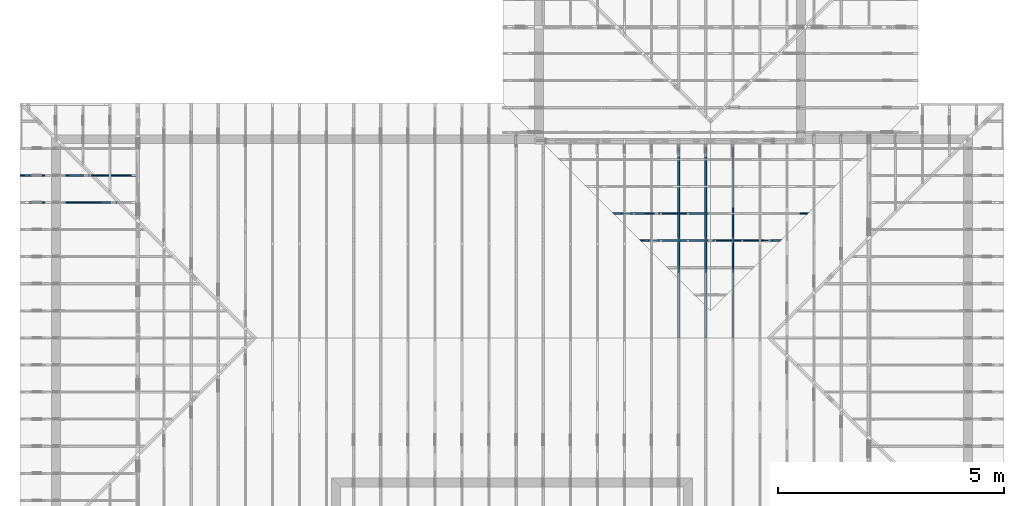
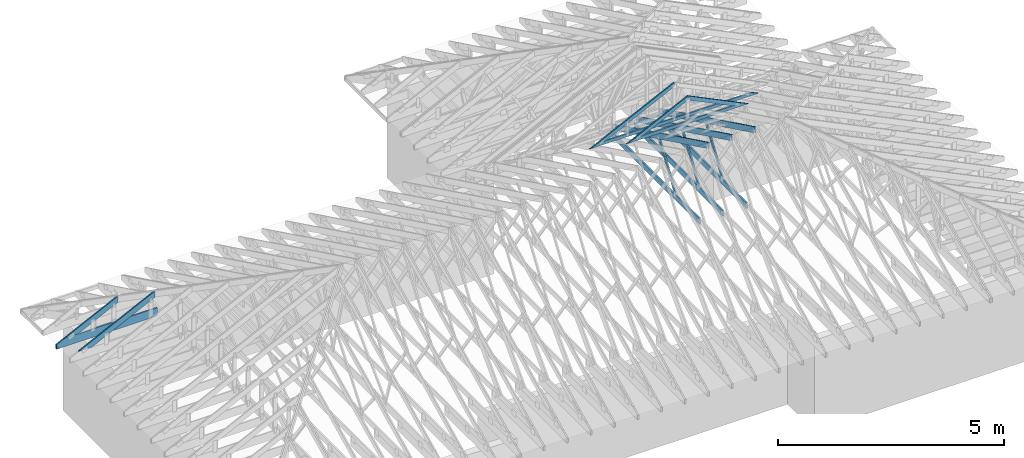
# One storey, part 19 of 159: 17 members, 7 elements without a shape of their own.
"""IFC2X3 building model written with IfcOpenShell, lengths in millimetres."""

from ifc_helpers import new_model, si_unit, frame, origin, origin_with_axes, origin_2d, place, context, project, spatial, faceted_brep, element, aggregate, save


model = new_model("IFC2X3")

# Units and contexts
model_context = context("Model", 3, precision=1e-05, world=origin())
plan_context = context("Plan", 2, precision=1e-05, world=origin_2d())
ifc_project = project(units=[si_unit("LENGTHUNIT", "METRE", prefix="MILLI"), si_unit("AREAUNIT", "SQUARE_METRE"), si_unit("VOLUMEUNIT", "CUBIC_METRE"), si_unit("SOLIDANGLEUNIT", "STERADIAN"), si_unit("PLANEANGLEUNIT", "RADIAN"), si_unit("MASSUNIT", "GRAM"), si_unit("TIMEUNIT", "SECOND"), si_unit("THERMODYNAMICTEMPERATUREUNIT", "DEGREE_CELSIUS"), si_unit("LUMINOUSINTENSITYUNIT", "LUMEN")], contexts=[model_context, plan_context])

# Site, building, storey
site_placement = place(None, origin_with_axes())
site = spatial("IfcSite", under=ifc_project, at=site_placement, CompositionType="ELEMENT")
building_placement = place(site_placement, origin_with_axes())
building = spatial("IfcBuilding", under=site, at=building_placement, Name="Plan 1", CompositionType="ELEMENT")
storey_placement = place(building_placement, origin_with_axes())
storey = spatial("IfcBuildingStorey", under=building, at=storey_placement, Name="Etasje 1", CompositionType="ELEMENT", Elevation=0.0)

# Assembly, members
assembly_1_placement = place(storey_placement, frame((15075.02226140475, -699.9989301294845, 1.1021457184401395e-15), z_axis=(-1.0, 1.836909530733566e-16, 6.123031769111886e-17), x_axis=(-1.836909530733566e-16, -1.0, 0.0)))
assembly_1 = element("IfcElementAssembly", 1, at=assembly_1_placement, inside=storey, Name="T7 (103)", AssemblyPlace="FACTORY", PredefinedType="TRUSS")
member_1_placement = place(assembly_1_placement, frame((-9411.999005287185, 437.2146234308699, -36.00000000000001), z_axis=(0.0, 0.0, 1.0), x_axis=(0.8987940462991673, 0.43837114678907735, 0.0)))
member_1 = element("IfcMember", 2, at=member_1_placement, Name="T7-O11", context=model_context, shape_type="Brep", body=[
    faceted_brep([(4758.463277584195, 148.00009154954296, 36.0), (72.18442876594781, 148.00009154954296, 36.0), (0.0, 4.140399232710479e-05, 36.0), (4686.278875574299, 4.140399232710479e-05, 36.0), (72.18442876594781, 148.00009154954296, 8.839751011381847e-15), (4758.463277584195, 148.00009154954296, 5.82724436416006e-13), (4686.278875574299, 4.140399232710479e-05, 5.738846886811872e-13), (0.0, 4.140399232710479e-05, 0.0), (8.360351420234293e-05, 5.140324472498181e-15, 7.179836740020234e-31), (8.360351420432413e-05, 4.174029286270475e-15, 36.0), (72.18450667705471, 147.99999999603824, 36.0), (72.18450667705471, 147.99999999603824, 1.530729119798975e-30), (4686.27888374885, 4.514103814251943e-05, -1.8242490005659002e-29), (4686.27888374885, 4.514103814472372e-05, 36.0), (8.360351421288216e-05, 2.204296752011599e-15, 36.0), (8.360351421288216e-05, 5.315131319929112e-21, -3.254471682622608e-37), (4758.463306857064, 148.00004514198963, 1.58299098763632e-28), (4758.463306857064, 148.00004514198963, 36.0), (4686.2788837488515, 4.5141036935092416e-05, 36.0), (4686.2788837488515, 4.5141036935092416e-05, 1.0730458735393999e-28), (72.18450667705474, 147.99999999603824, 0.0), (72.18450667705474, 147.99999999603824, 36.0), (4758.463306857063, 148.00004514199048, 36.0), (4758.463306857063, 148.00004514199048, -2.8398992587956425e-29)], [[[0, 1, 2, 3]], [[4, 5, 6, 7]], [[8, 9, 10, 11]], [[12, 13, 14, 15]], [[16, 17, 18, 19]], [[20, 21, 22, 23]]]),
])
member_2_placement = place(assembly_1_placement, frame((-5591.18115234375, 371.0, -36.0), z_axis=(0.0, 0.0, 1.0), x_axis=(-1.0, 1.2246063538223773e-16, 0.0)))
member_2 = element("IfcMember", 3, at=member_2_placement, Name="T7-U39", context=model_context, shape_type="Brep", body=[
    faceted_brep([(3910.81787109375, 148.00000000000048, 36.0), (0.0, 148.00000000000048, 36.0), (0.0, 0.0, 36.0), (3910.81787109375, 0.0, 36.0), (0.0, 148.00000000000048, 0.0), (3910.81787109375, 148.00000000000048, 4.789212413583509e-13), (3910.81787109375, 0.0, 4.789212413583509e-13), (0.0, 0.0, 0.0), (0.0001433398574590683, 3.979039320256561e-13, 0.0), (0.0001433398574612726, 3.979039320256561e-13, 36.0), (0.00014333985747939676, 148.00000000000037, 36.0), (0.00014333985747719247, 148.00000000000037, -1.1097494219785373e-30), (3910.817777776101, -3.204779149536956e-13, 4.746728930957506e-29), (3910.817777776101, -3.182736235168153e-13, 36.0), (0.0001433398574590683, 4.001081950488681e-13, 36.0), (0.0001433398574590683, 3.9790390361198783e-13, 1.73977793531565e-36), (3910.817777776101, 148.00000000000048, 0.0), (3910.817777776101, 148.00000000000048, 36.0), (3910.817777776101, 4.547473508864641e-13, 36.0), (3910.817777776101, 4.547473508864641e-13, 0.0), (0.0001433398574590683, 148.00000000000037, 0.0), (0.0001433398574590683, 148.00000000000037, 36.0), (3910.817777776101, 148.0000000000001, 36.0), (3910.817777776101, 148.00000000000014, -2.208810534618833e-29)], [[[0, 1, 2, 3]], [[4, 5, 6, 7]], [[8, 9, 10, 11]], [[12, 13, 14, 15]], [[16, 17, 18, 19]], [[20, 21, 22, 23]]]),
])
member_3_placement = place(assembly_1_placement, frame((-7407.03695472166, 1415.0999762480442, -36.0), z_axis=(0.0, 0.0, 1.0), x_axis=(0.5642475050064201, -0.8256056886274645, 0.0)))
member_3 = element("IfcMember", 4, at=member_3_placement, Name="T7-D42", context=model_context, shape_type="Brep", body=[
    faceted_brep([(1236.1859046255386, 72.99999679664234, 36.0), (10.714742691100582, 72.99999679664234, 36.0), (8.80134111866937e-05, 0.0003439493775658775, 36.0), (1264.647265190018, 0.0003439493775658775, 36.0), (10.714742691100582, 72.99999679664234, 1.312134197909365e-15), (1236.1859046255386, 72.99999679664234, 1.5138411133100978e-13), (1264.647265190018, 0.0003439493775658775, 1.548695076295789e-13), (8.80134111866937e-05, 0.0003439493775658775, 1.077817825608066e-20), (1.2441219929271163e-16, 0.00017519218454252033, -7.699393958337917e-33), (2.305335691224139e-15, 0.00017519218454220022, 36.0), (10.714685884795475, 73.00017519218454, 36.0), (10.714685884795474, 73.00017519218454, -2.956283656724794e-32), (1264.6473849224226, 0.00017519218655669935, 4.373824669985916e-29), (1264.6473849224226, 0.00017519218655890365, 36.0), (-3.510681399126273e-30, 0.0001751921845447429, 36.0), (0.0, 0.0001751921845425386, 0.0), (1236.1860298802894, 73.00017519218727, -1.3795914725131465e-29), (1236.1860298802894, 73.00017519218727, 36.0), (1264.6473849224226, 0.0001751921872710227, 36.0), (1264.6473849224226, 0.0001751921872710227, -1.4037355718167356e-29), (10.714685884795474, 73.00017519218454, 0.0), (10.714685884795474, 73.00017519218453, 36.0), (1236.1860298802894, 73.00017519218719, 36.0), (1236.1860298802894, 73.00017519218719, -5.5220263365470826e-30)], [[[0, 1, 2, 3]], [[4, 5, 6, 7]], [[8, 9, 10, 11]], [[12, 13, 14, 15]], [[16, 17, 18, 19]], [[20, 21, 22, 23]]]),
])
aggregate(assembly_1, [member_1, member_2, member_3])

assembly_2_placement = place(storey_placement, frame((14475.022261404752, -699.9989301294836, 1.1021457184401395e-15), z_axis=(-1.0, 1.836909530733566e-16, 6.123031769111886e-17), x_axis=(-1.836909530733566e-16, -1.0, 0.0)))
assembly_2 = element("IfcElementAssembly", 5, at=assembly_2_placement, inside=storey, Name="T10 (102)", AssemblyPlace="FACTORY", PredefinedType="TRUSS")
member_4_placement = place(assembly_2_placement, frame((-9411.999005287185, 437.2146234308699, -36.00000000000001), z_axis=(0.0, 0.0, 1.0), x_axis=(0.8987940462991673, 0.43837114678907735, 0.0)))
member_4 = element("IfcMember", 6, at=member_4_placement, Name="T10-O11", context=model_context, shape_type="Brep", body=[
    faceted_brep([(4758.463277584195, 148.00009154954296, 36.0), (72.18442876594781, 148.00009154954296, 36.0), (0.0, 4.140399232710479e-05, 36.0), (4686.278875574299, 4.140399232710479e-05, 36.0), (72.18442876594781, 148.00009154954296, 8.839751011381847e-15), (4758.463277584195, 148.00009154954296, 5.82724436416006e-13), (4686.278875574299, 4.140399232710479e-05, 5.738846886811872e-13), (0.0, 4.140399232710479e-05, 0.0), (8.360351420234293e-05, 5.140324472498181e-15, 7.179836740020234e-31), (8.360351420432413e-05, 4.174029286270475e-15, 36.0), (72.18450667705471, 147.99999999603824, 36.0), (72.18450667705471, 147.99999999603824, 1.530729119798975e-30), (4686.27888374885, 4.514103814251943e-05, -1.8242490005659002e-29), (4686.27888374885, 4.514103814472372e-05, 36.0), (8.360351421288216e-05, 2.204296752011599e-15, 36.0), (8.360351421288216e-05, 5.315131319929112e-21, -3.254471682622608e-37), (4758.463306857064, 148.00004514198963, 1.58299098763632e-28), (4758.463306857064, 148.00004514198963, 36.0), (4686.2788837488515, 4.5141036935092416e-05, 36.0), (4686.2788837488515, 4.5141036935092416e-05, 1.0730458735393999e-28), (72.18450667705474, 147.99999999603824, 0.0), (72.18450667705474, 147.99999999603824, 36.0), (4758.463306857063, 148.00004514199048, 36.0), (4758.463306857063, 148.00004514199048, -2.8398992587956425e-29)], [[[0, 1, 2, 3]], [[4, 5, 6, 7]], [[8, 9, 10, 11]], [[12, 13, 14, 15]], [[16, 17, 18, 19]], [[20, 21, 22, 23]]]),
])
member_5_placement = place(assembly_2_placement, frame((-5591.18115234375, 371.0, -36.0), z_axis=(0.0, 0.0, 1.0), x_axis=(-1.0, 1.2246063538223773e-16, 0.0)))
member_5 = element("IfcMember", 7, at=member_5_placement, Name="T10-U39", context=model_context, shape_type="Brep", body=[
    faceted_brep([(3910.81787109375, 148.00000000000048, 36.0), (0.0, 148.00000000000048, 36.0), (0.0, 0.0, 36.0), (3910.81787109375, 0.0, 36.0), (0.0, 148.00000000000048, 0.0), (3910.81787109375, 148.00000000000048, 4.789212413583509e-13), (3910.81787109375, 0.0, 4.789212413583509e-13), (0.0, 0.0, 0.0), (0.0001433398574590683, 3.979039320256561e-13, 0.0), (0.0001433398574612726, 3.979039320256561e-13, 36.0), (0.00014333985747939676, 148.00000000000037, 36.0), (0.00014333985747719247, 148.00000000000037, -1.1097494219785373e-30), (3910.817777776101, -3.204779149536956e-13, 4.746728930957506e-29), (3910.817777776101, -3.182736235168153e-13, 36.0), (0.0001433398574590683, 4.001081950488681e-13, 36.0), (0.0001433398574590683, 3.9790390361198783e-13, 1.73977793531565e-36), (3910.817777776101, 148.00000000000048, 0.0), (3910.817777776101, 148.00000000000048, 36.0), (3910.817777776101, 4.547473508864641e-13, 36.0), (3910.817777776101, 4.547473508864641e-13, 0.0), (0.0001433398574590683, 148.00000000000037, 0.0), (0.0001433398574590683, 148.00000000000037, 36.0), (3910.817777776101, 148.0000000000001, 36.0), (3910.817777776101, 148.00000000000014, -2.208810534618833e-29)], [[[0, 1, 2, 3]], [[4, 5, 6, 7]], [[8, 9, 10, 11]], [[12, 13, 14, 15]], [[16, 17, 18, 19]], [[20, 21, 22, 23]]]),
])
member_6_placement = place(assembly_2_placement, frame((-7407.03695472166, 1415.0999762480442, -36.0), z_axis=(0.0, 0.0, 1.0), x_axis=(0.5642475050064201, -0.8256056886274645, 0.0)))
member_6 = element("IfcMember", 8, at=member_6_placement, Name="T10-D42", context=model_context, shape_type="Brep", body=[
    faceted_brep([(1236.1859046255386, 72.99999679664234, 36.0), (10.714742691100582, 72.99999679664234, 36.0), (8.80134111866937e-05, 0.0003439493775658775, 36.0), (1264.647265190018, 0.0003439493775658775, 36.0), (10.714742691100582, 72.99999679664234, 1.312134197909365e-15), (1236.1859046255386, 72.99999679664234, 1.5138411133100978e-13), (1264.647265190018, 0.0003439493775658775, 1.548695076295789e-13), (8.80134111866937e-05, 0.0003439493775658775, 1.077817825608066e-20), (1.2441219929271163e-16, 0.00017519218454252033, -7.699393958337917e-33), (2.305335691224139e-15, 0.00017519218454220022, 36.0), (10.714685884795475, 73.00017519218454, 36.0), (10.714685884795474, 73.00017519218454, -2.956283656724794e-32), (1264.6473849224226, 0.00017519218655669935, 4.373824669985916e-29), (1264.6473849224226, 0.00017519218655890365, 36.0), (-3.510681399126273e-30, 0.0001751921845447429, 36.0), (0.0, 0.0001751921845425386, 0.0), (1236.1860298802894, 73.00017519218727, -1.3795914725131465e-29), (1236.1860298802894, 73.00017519218727, 36.0), (1264.6473849224226, 0.0001751921872710227, 36.0), (1264.6473849224226, 0.0001751921872710227, -1.4037355718167356e-29), (10.714685884795474, 73.00017519218454, 0.0), (10.714685884795474, 73.00017519218453, 36.0), (1236.1860298802894, 73.00017519218719, 36.0), (1236.1860298802894, 73.00017519218719, -5.5220263365470826e-30)], [[[0, 1, 2, 3]], [[4, 5, 6, 7]], [[8, 9, 10, 11]], [[12, 13, 14, 15]], [[16, 17, 18, 19]], [[20, 21, 22, 23]]]),
])
aggregate(assembly_2, [member_4, member_5, member_6])

assembly_3_placement = place(storey_placement, frame((13875.022261404752, -699.9989301294836, 1.1021457184401395e-15), z_axis=(-1.0, 1.836909530733566e-16, 6.123031769111886e-17), x_axis=(-1.836909530733566e-16, -1.0, 0.0)))
assembly_3 = element("IfcElementAssembly", 9, at=assembly_3_placement, inside=storey, Name="T6 (101)", AssemblyPlace="FACTORY", PredefinedType="TRUSS")
member_7_placement = place(assembly_3_placement, frame((-9411.999005287185, 437.2146234308699, -36.00000000000001), z_axis=(0.0, 0.0, 1.0), x_axis=(0.8987940462991673, 0.43837114678907735, 0.0)))
member_7 = element("IfcMember", 10, at=member_7_placement, Name="T6-O11", context=model_context, shape_type="Brep", body=[
    faceted_brep([(4758.463277584195, 148.00009154954296, 36.0), (72.18442876594781, 148.00009154954296, 36.0), (0.0, 4.140399232710479e-05, 36.0), (4686.278875574299, 4.140399232710479e-05, 36.0), (72.18442876594781, 148.00009154954296, 8.839751011381847e-15), (4758.463277584195, 148.00009154954296, 5.82724436416006e-13), (4686.278875574299, 4.140399232710479e-05, 5.738846886811872e-13), (0.0, 4.140399232710479e-05, 0.0), (8.360351420234293e-05, 5.140324472498181e-15, 7.179836740020234e-31), (8.360351420432413e-05, 4.174029286270475e-15, 36.0), (72.18450667705471, 147.99999999603824, 36.0), (72.18450667705471, 147.99999999603824, 1.530729119798975e-30), (4686.27888374885, 4.514103814251943e-05, -1.8242490005659002e-29), (4686.27888374885, 4.514103814472372e-05, 36.0), (8.360351421288216e-05, 2.204296752011599e-15, 36.0), (8.360351421288216e-05, 5.315131319929112e-21, -3.254471682622608e-37), (4758.463306857064, 148.00004514198963, 1.58299098763632e-28), (4758.463306857064, 148.00004514198963, 36.0), (4686.2788837488515, 4.5141036935092416e-05, 36.0), (4686.2788837488515, 4.5141036935092416e-05, 1.0730458735393999e-28), (72.18450667705474, 147.99999999603824, 0.0), (72.18450667705474, 147.99999999603824, 36.0), (4758.463306857063, 148.00004514199048, 36.0), (4758.463306857063, 148.00004514199048, -2.8398992587956425e-29)], [[[0, 1, 2, 3]], [[4, 5, 6, 7]], [[8, 9, 10, 11]], [[12, 13, 14, 15]], [[16, 17, 18, 19]], [[20, 21, 22, 23]]]),
])
member_8_placement = place(assembly_3_placement, frame((-5591.18115234375, 371.0, -36.0), z_axis=(0.0, 0.0, 1.0), x_axis=(-1.0, 1.2246063538223773e-16, 0.0)))
member_8 = element("IfcMember", 11, at=member_8_placement, Name="T6-U39", context=model_context, shape_type="Brep", body=[
    faceted_brep([(3910.81787109375, 148.00000000000048, 36.0), (0.0, 148.00000000000048, 36.0), (0.0, 0.0, 36.0), (3910.81787109375, 0.0, 36.0), (0.0, 148.00000000000048, 0.0), (3910.81787109375, 148.00000000000048, 4.789212413583509e-13), (3910.81787109375, 0.0, 4.789212413583509e-13), (0.0, 0.0, 0.0), (0.0001433398574590683, 3.979039320256561e-13, 0.0), (0.0001433398574612726, 3.979039320256561e-13, 36.0), (0.00014333985747939676, 148.00000000000037, 36.0), (0.00014333985747719247, 148.00000000000037, -1.1097494219785373e-30), (3910.817777776101, -3.204779149536956e-13, 4.746728930957506e-29), (3910.817777776101, -3.182736235168153e-13, 36.0), (0.0001433398574590683, 4.001081950488681e-13, 36.0), (0.0001433398574590683, 3.9790390361198783e-13, 1.73977793531565e-36), (3910.817777776101, 148.00000000000048, 0.0), (3910.817777776101, 148.00000000000048, 36.0), (3910.817777776101, 4.547473508864641e-13, 36.0), (3910.817777776101, 4.547473508864641e-13, 0.0), (0.0001433398574590683, 148.00000000000037, 0.0), (0.0001433398574590683, 148.00000000000037, 36.0), (3910.817777776101, 148.0000000000001, 36.0), (3910.817777776101, 148.00000000000014, -2.208810534618833e-29)], [[[0, 1, 2, 3]], [[4, 5, 6, 7]], [[8, 9, 10, 11]], [[12, 13, 14, 15]], [[16, 17, 18, 19]], [[20, 21, 22, 23]]]),
])
member_9_placement = place(assembly_3_placement, frame((-7407.03695472166, 1415.0999762480442, -36.0), z_axis=(0.0, 0.0, 1.0), x_axis=(0.5642475050064201, -0.8256056886274645, 0.0)))
member_9 = element("IfcMember", 12, at=member_9_placement, Name="T6-D42", context=model_context, shape_type="Brep", body=[
    faceted_brep([(1236.1859046255386, 72.99999679664234, 36.0), (10.714742691100582, 72.99999679664234, 36.0), (8.80134111866937e-05, 0.0003439493775658775, 36.0), (1264.647265190018, 0.0003439493775658775, 36.0), (10.714742691100582, 72.99999679664234, 1.312134197909365e-15), (1236.1859046255386, 72.99999679664234, 1.5138411133100978e-13), (1264.647265190018, 0.0003439493775658775, 1.548695076295789e-13), (8.80134111866937e-05, 0.0003439493775658775, 1.077817825608066e-20), (1.2441219929271163e-16, 0.00017519218454252033, -7.699393958337917e-33), (2.305335691224139e-15, 0.00017519218454220022, 36.0), (10.714685884795475, 73.00017519218454, 36.0), (10.714685884795474, 73.00017519218454, -2.956283656724794e-32), (1264.6473849224226, 0.00017519218655669935, 4.373824669985916e-29), (1264.6473849224226, 0.00017519218655890365, 36.0), (-3.510681399126273e-30, 0.0001751921845447429, 36.0), (0.0, 0.0001751921845425386, 0.0), (1236.1860298802894, 73.00017519218727, -1.3795914725131465e-29), (1236.1860298802894, 73.00017519218727, 36.0), (1264.6473849224226, 0.0001751921872710227, 36.0), (1264.6473849224226, 0.0001751921872710227, -1.4037355718167356e-29), (10.714685884795474, 73.00017519218454, 0.0), (10.714685884795474, 73.00017519218453, 36.0), (1236.1860298802894, 73.00017519218719, 36.0), (1236.1860298802894, 73.00017519218719, -5.5220263365470826e-30)], [[[0, 1, 2, 3]], [[4, 5, 6, 7]], [[8, 9, 10, 11]], [[12, 13, 14, 15]], [[16, 17, 18, 19]], [[20, 21, 22, 23]]]),
])
aggregate(assembly_3, [member_7, member_8, member_9])

assembly_4_placement = place(storey_placement, frame((-700.000000000007, 8081.993668449246, 1.1021457184401395e-15), z_axis=(0.0, -1.0, 6.123031769111886e-17), x_axis=(1.0, 0.0, 0.0)))
assembly_4 = element("IfcElementAssembly", 13, at=assembly_4_placement, inside=storey, Name="S7 (14)", AssemblyPlace="FACTORY", PredefinedType="TRUSS")
member_10_placement = place(assembly_4_placement, frame((276.06017491049846, 89.97845651718738, -36.000000217690726), z_axis=(0.0, 0.0, 1.0), x_axis=(0.898794046299167, 0.4383711467890774, 0.0)))
member_10 = element("IfcMember", 14, at=member_10_placement, Name="S7-O62", context=model_context, shape_type="Brep", body=[
    faceted_brep([(1508.5918787073251, 147.99999481679464, 36.00000324769576), (1436.4074547564246, 2.2737367544323206e-13, 36.000000217691195), (1396.3537848139886, 3.2104094316309784e-07, 4.547473508864641e-13), (1468.5382087648895, 147.99999513783558, 3.030005132131919e-06), (8.09896368423324e-05, 148.0000000009527, 2.1769072588995184e-07), (8.09896368423324e-05, 148.0000000009528, 36.00000021769072), (1508.5918778646371, 148.00000000095272, 36.00000021769072), (1468.5382088888068, 148.0000000009526, 2.1769072588995184e-07), (0.0, 148.00000000096017, 2.1769072588995186e-07), (1468.5382080078125, 148.00000000096017, 2.176909057280739e-07), (1396.3537826538088, 9.52809386944864e-10, 2.176908968883233e-07), (303.44506835937506, 9.52809386944864e-10, 2.1769076305002775e-07), (303.4450247385612, 8.118661298794905e-10, 2.1769072588995186e-07), (303.4450247385612, 8.118661298794905e-10, 36.000000217690726), (5.302542993490533e-05, 148.0000015417521, 36.000000217690726), (5.302542993490533e-05, 148.0000015417521, 2.1769072588995186e-07), (1436.4074538754444, 2.8237432538507385e-11, 36.000000217690726), (303.44497142305175, 2.844554749670542e-11, 36.000000217690726), (303.44497142305175, 2.844334320526854e-11, 2.1769072588995186e-07), (1396.3537848996143, 2.824258574369876e-11, 2.1769072588995186e-07), (1508.591880110429, 148.0000000000001, 36.000000217690726), (0.0001061236122268383, 148.0000000000001, 36.000000217690726), (303.4450524126748, 8.119513950077817e-10, 36.000000217690726), (1436.407454756425, 8.119513950077817e-10, 36.000000217690726)], [[[0, 1, 2, 3]], [[4, 5, 6, 7]], [[8, 9, 10, 11]], [[12, 13, 14, 15]], [[16, 17, 18, 19]], [[20, 21, 22, 23]]]),
])
member_11_placement = place(assembly_4_placement, frame((2575.022261404756, 223.00000000093104, -36.0), z_axis=(0.0, 0.0, 1.0), x_axis=(-1.0, 1.2246063538223773e-16, 0.0)))
member_11 = element("IfcMember", 15, at=member_11_placement, Name="S7-U11", context=model_context, shape_type="Brep", body=[
    faceted_brep([(2575.022261404767, 223.00000000093135, 36.0), (4.4607881136471406e-05, 223.00000000093135, 36.0), (4.4607881136471406e-05, 9.310383575211745e-10, 36.0), (2363.8409717319046, 9.310383575211745e-10, 36.0), (2575.0222614047602, 103.00000000093135, 36.0), (4.4607881136471406e-05, 223.00000000093135, 5.462709467027625e-21), (2575.022261404767, 223.00000000093135, 3.1533886225503443e-13), (2575.0222614047602, 103.00000000093135, 3.1533886225503357e-13), (2363.8409717319046, 9.310383575211745e-10, 2.8947746734085526e-13), (4.4607881136471406e-05, 9.310383575211745e-10, 5.462709467027625e-21), (1.1401554882727804e-25, 9.310383575211745e-10, -6.981208276421509e-42), (2.2042914369942947e-15, 9.310383575211745e-10, 36.0), (2.9513013127233304e-14, 223.00000000093104, 36.0), (2.730872169035303e-14, 223.00000000093104, -1.6721217048386645e-30), (2363.8409657211487, 5.200890442812092e-13, -3.184521740901289e-29), (2363.8409657211487, 5.222933357180895e-13, 36.0), (8.67712118026388e-28, 9.310405618126114e-10, 36.0), (0.0, 9.310383575211745e-10, 0.0), (2575.0222614047602, 103.00000000064097, -5.048709793414476e-29), (2575.0222614047602, 103.00000000064097, 36.0), (2363.840965721148, 4.547473508864641e-13, 36.0), (2363.840965721148, 4.547473508864641e-13, -3.7865323450608567e-29), (2575.0222614047543, 223.00000000093135, -7.825500179792437e-28), (2575.0222614047543, 223.00000000093135, 36.0), (2575.0222614047543, 103.00000000064031, 36.0), (2575.0222614047543, 103.00000000064031, -3.534096855390133e-28), (0.0, 223.00000000093104, 0.0), (0.0, 223.00000000093104, 36.0), (2575.022261404767, 223.00000000093144, 36.0), (2575.022261404767, 223.00000000093146, 6.310887241768095e-30)], [[[0, 1, 2, 3, 4]], [[5, 6, 7, 8, 9]], [[10, 11, 12, 13]], [[14, 15, 16, 17]], [[18, 19, 20, 21]], [[22, 23, 24, 25]], [[26, 27, 28, 29]]]),
])
aggregate(assembly_4, [member_10, member_11])

# Assembly, member
assembly_5_placement = place(storey_placement, frame((-700.000000000007, 7481.993668449246, 1.1021457184401395e-15), z_axis=(0.0, -1.0, 6.123031769111886e-17), x_axis=(1.0, 0.0, 0.0)))
assembly_5 = element("IfcElementAssembly", 16, at=assembly_5_placement, inside=storey, Name="S6 (12)", AssemblyPlace="FACTORY", PredefinedType="TRUSS")
member_12_placement = place(assembly_5_placement, frame((276.0601443311933, 89.97844160320304, -36.000000217727774), z_axis=(0.0, 0.0, 1.0), x_axis=(0.898794046299167, 0.4383711467890774, 0.0)))
member_12 = element("IfcMember", 17, at=member_12_placement, Name="S6-O53", context=model_context, shape_type="Brep", body=[
    faceted_brep([(2176.1530770153477, 147.9999948175231, 36.00000324767268), (2103.96865306448, 7.128164725145325e-10, 36.000000217727575), (2063.9149831220775, 3.2171402608582866e-07, -2.2737367544323206e-13), (2136.099407072945, 147.99999513852458, 3.029944537047413e-06), (5.684341886080802e-14, 147.99999999999145, 2.177277735881944e-07), (5.684341886080802e-14, 147.99999999999133, 36.000000217727774), (2176.153076171875, 147.99999999999122, 36.000000217727774), (2136.099407196045, 147.9999999999913, 2.177277735881944e-07), (4.1080787525515916e-05, 148.00000000047558, 2.1772777358819942e-07), (2136.099406315163, 148.00000000047558, 2.1772803517628494e-07), (2063.914980961159, 2.842170943040401e-14, 2.1772802633653433e-07), (303.44510944016275, 2.842170943040401e-14, 2.177278107482753e-07), (303.445058760919, 3.270770321250893e-10, 2.177277735881944e-07), (303.445058760919, 3.270770321250893e-10, 36.000000217727774), (8.704778765888932e-05, 148.00000154126735, 36.000000217727774), (8.704778765888932e-05, 148.00000154126735, 2.177277735881944e-07), (2103.968652183589, 7.036067700739913e-10, 36.000000217727774), (303.44501250463355, 7.03937509977395e-10, 36.000000217727774), (303.44501250463355, 7.039353056859582e-10, 2.177277735881944e-07), (2063.9149832077587, 7.036119232791827e-10, 2.177277735881944e-07), (2176.1530784184833, 148.00000000071284, 36.000000217727774), (0.00014720510444021784, 148.00000000071284, 36.000000217727774), (303.4450934941669, 3.2727598409110215e-10, 36.000000217727774), (2103.9686530644794, 3.2727598409110215e-10, 36.000000217727774)], [[[0, 1, 2, 3]], [[4, 5, 6, 7]], [[8, 9, 10, 11]], [[12, 13, 14, 15]], [[16, 17, 18, 19]], [[20, 21, 22, 23]]]),
])
aggregate(assembly_5, [member_12])

# Assembly, members
assembly_6_placement = place(storey_placement, frame((12446.012607049342, 7236.0000560521385, 1312.9938842936408), z_axis=(0.0, -1.0, 6.123031769111886e-17), x_axis=(1.0, 0.0, 0.0)))
assembly_6 = element("IfcElementAssembly", 18, at=assembly_6_placement, inside=storey, Name="Tr3 (84)", AssemblyPlace="FACTORY", PredefinedType="TRUSS")
member_13_placement = place(assembly_6_placement, frame((225.89018179364817, 1.139010648036006, -36.0), z_axis=(0.0, 0.0, 1.0), x_axis=(0.898794046299167, 0.4383711467890774, 0.0)))
member_13 = element("IfcMember", 19, at=member_13_placement, Name="Tr3-O83", context=model_context, shape_type="Brep", body=[
    faceted_brep([(2193.0165435528734, 98.00005061742615, 36.0), (2.6177286827078206e-06, 98.00005061742615, 36.0), (200.92978933910462, 0.0, 36.0), (2145.2187305793377, 0.0, 36.0), (2.6177286827078206e-06, 98.00005061742615, 3.205687177427079e-22), (2193.0165435528734, 98.00005061742615, 2.685581993272437e-13), (2145.2187305793377, 0.0, 2.6270484878062314e-13), (200.92978933910462, 0.0, 2.4605989669685926e-14), (200.92977647567355, 2.051961658366963e-06, 3.711943346046518e-30), (200.92977647567355, 2.051961658366963e-06, 36.0), (7.105427357601002e-15, 98.00000205240194, 36.0), (7.105427357601002e-15, 98.00000205240194, -9.212427761517614e-31), (2145.2187885507633, 2.0531581903280273e-06, -7.957513719272833e-29), (2145.2187885507633, 2.0531581925323188e-06, 36.0), (200.92977647567358, 2.0519618249298863e-06, 36.0), (200.92977647567358, 2.051961822725595e-06, -7.453325798069553e-30), (2193.0165822305134, 98.00000205376546, -2.200972149979091e-29), (2193.0165822305134, 98.00000205376546, 36.0), (2145.218788550763, 2.0531570044113323e-06, 36.0), (2145.218788550763, 2.0531570044113323e-06, -2.2345711503869415e-29), (0.0, 98.00000205240192, 0.0), (0.0, 98.00000205240192, 36.0), (2193.016582230514, 98.00000205376573, 36.0), (2193.016582230514, 98.00000205376573, 2.4454688061851366e-29)], [[[0, 1, 2, 3]], [[4, 5, 6, 7]], [[8, 9, 10, 11]], [[12, 13, 14, 15]], [[16, 17, 18, 19]], [[20, 21, 22, 23]]]),
])
member_14_placement = place(assembly_6_placement, frame((4326.0000804539495, 89.22082935521951, -36.000000000000014), z_axis=(0.0, 0.0, 1.0), x_axis=(-1.0, 1.2246063538223773e-16, 0.0)))
member_14 = element("IfcMember", 20, at=member_14_placement, Name="Tr3-U45", context=model_context, shape_type="Brep", body=[
    faceted_brep([(4.842017824557842e-05, 98.00000032472107, 3.2035746897918216e-05), (36.000048420178246, 80.44164257295768, 36.00000038601682), (4308.000078937756, 80.44164257295746, 36.00000038601672), (4344.000048420178, 98.00000032472096, 3.203574659238484e-05), (4308.0000804559195, 80.44164276123048, 36.000000000000014), (36.00008045591949, 80.44164276123048, 36.000000000000014), (200.9297679559195, 0.0, 36.000000000000014), (4143.070270885607, 0.0, 36.000000000000014), (200.92977300654002, 2.2038561979798033e-06, 3.552713678800506e-14), (200.92977300653996, 2.203856070082111e-06, 36.00000000000001), (35.99996835021012, 80.44164276123013, 36.00000000000001), (2.1316282072803006e-14, 98.00000051311586, 3.051757813210543e-05), (4143.070271945345, 3.247203813750215e-07, 1.421085471520205e-14), (4143.070271945345, 3.2472038357931296e-07, 36.000000000000014), (200.92989108596976, 3.247211077148367e-07, 36.000000000000014), (200.92989108596976, 3.2472110551054524e-07, 1.4210854715202007e-14), (4344.000048420177, 98.0000003247228, 3.203574669186082e-05), (4308.000080069906, 80.4416425729612, 36.00000151816857), (4143.070275413298, 2.0161567135801306e-06, 36.000001518168574), (4143.070275413298, 2.0161567135801306e-06, 2.4233807008389483e-27), (4.842017824557843e-05, 98.00000032472065, 1.4210860644767796e-14), (4344.000048420178, 98.00000032472065, 5.461798607452084e-13), (4143.070269367444, 3.2472117084125784e-07, 5.21573872335198e-13), (200.92973592017825, 3.2472117084125784e-07, 3.881683784317226e-14)], [[[0, 1, 2, 3]], [[4, 5, 6, 7]], [[8, 9, 10, 11]], [[12, 13, 14, 15]], [[16, 17, 18, 19]], [[20, 21, 22, 23]]]),
])
aggregate(assembly_6, [member_13, member_14])

assembly_7_placement = place(storey_placement, frame((13046.012612936298, 6636.000050165183, 1605.6334403044173), z_axis=(0.0, -1.0, 6.123031769111886e-17), x_axis=(1.0, 0.0, 0.0)))
assembly_7 = element("IfcElementAssembly", 21, at=assembly_7_placement, inside=storey, Name="Tr4 (108)", AssemblyPlace="FACTORY", PredefinedType="TRUSS")
member_15_placement = place(assembly_7_placement, frame((225.89018179364803, 1.1390106480359208, -36.0), z_axis=(0.0, 0.0, 1.0), x_axis=(0.898794046299167, 0.4383711467890774, 0.0)))
member_15 = element("IfcMember", 22, at=member_15_placement, Name="Tr4-O84", context=model_context, shape_type="Brep", body=[
    faceted_brep([(1525.4553642479254, 98.00001982220135, 36.0), (2.617728853238077e-06, 98.00001982220135, 36.0), (200.9297893391048, 0.0, 36.0), (1477.657578030441, 0.0, 36.0), (2.617728853238077e-06, 98.00001982220135, 3.2056873862595146e-22), (1525.4553642479254, 98.00001982220135, 1.8680823315304383e-13), (1477.657578030441, 0.0, 1.8095488588298632e-13), (200.9297893391048, 0.0, 2.4605989669685948e-14), (200.92977647734776, 2.0511447473836597e-06, 2.9230824408312468e-30), (200.92977647734776, 2.0511447473836597e-06, 36.0), (7.105427357601002e-15, 98.00000205240161, 36.0), (7.105427357601002e-15, 98.0000020524016, -9.21242776151761e-31), (1477.6576177156326, 2.0527899026605515e-06, 1.4347821934406495e-29), (1477.6576177156326, 2.052789904864843e-06, 36.0), (200.9297764773478, 2.051144760357274e-06, 36.0), (200.9297764773478, 2.0511447581529827e-06, 1.9509963740032664e-30), (1525.4554113945676, 98.00000205172421, 1.262177448353619e-29), (1525.4554113945676, 98.00000205172421, 36.0), (1477.6576177156328, 2.052789909612329e-06, 36.0), (1477.6576177156328, 2.052789909612329e-06, 1.262177448353619e-29), (0.0, 98.00000205240158, 0.0), (0.0, 98.00000205240158, 36.0), (1525.4554113945674, 98.0000020517244, 36.0), (1525.4554113945674, 98.0000020517244, 3.944304526105059e-30)], [[[0, 1, 2, 3]], [[4, 5, 6, 7]], [[8, 9, 10, 11]], [[12, 13, 14, 15]], [[16, 17, 18, 19]], [[20, 21, 22, 23]]]),
])
member_16_placement = place(assembly_7_placement, frame((1511.0396306542698, 669.8546520971279, -36.0), z_axis=(0.0, 0.0, 1.0), x_axis=(0.8987940462991671, -0.438371146789077, 0.0)))
member_16 = element("IfcMember", 23, at=member_16_placement, Name="Tr4-O84", context=model_context, shape_type="Brep", body=[
    faceted_brep([(1525.4554713462664, 98.00003175365464, 36.0), (0.0, 98.00003175365464, 36.0), (47.79778621748437, 8.365456324099796e-06, 36.0), (1324.5256297668554, 8.365456324099796e-06, 36.0), (0.0, 98.00003175365464, 0.0), (1525.4554713462664, 98.00003175365464, 1.8680824626837473e-13), (1324.5256297668554, 8.365456324099796e-06, 1.6220225020130768e-13), (47.79778621748437, 8.365456324099796e-06, 5.853347270057502e-15), (47.79783670944879, 1.927700463610904e-05, 7.242939492485795e-31), (47.797836709448795, 1.927700463610904e-05, 36.0), (4.3029697977203796e-05, 98.00001927761286, 36.0), (4.3029697977203796e-05, 98.00001927761286, -9.118683097254457e-31), (1324.5256779495, 1.9278291430528778e-05, 3.6669816731641496e-29), (1324.5256779495, 1.927829143273307e-05, 36.0), (47.7978367094488, 1.9277004620254288e-05, 36.0), (47.7978367094488, 1.9277004618049997e-05, 1.3232946158054135e-30), (1525.455454421825, 98.00001927709957, -2.524354896707238e-29), (1525.455454421825, 98.00001927709957, 36.0), (1324.5256779495003, 1.9278292370472627e-05, 36.0), (1324.5256779495003, 1.9278292370472627e-05, -1.8932661725304283e-29), (4.302969796299294e-05, 98.00001927761286, 0.0), (4.302969796299294e-05, 98.00001927761286, 36.0), (1525.4554544218252, 98.00001927709927, 36.0), (1525.4554544218252, 98.00001927709927, 3.1554436208840472e-30)], [[[0, 1, 2, 3]], [[4, 5, 6, 7]], [[8, 9, 10, 11]], [[12, 13, 14, 15]], [[16, 17, 18, 19]], [[20, 21, 22, 23]]]),
])
member_17_placement = place(assembly_7_placement, frame((3126.0000686816265, 89.2208293551721, -36.00000000000124), z_axis=(0.0, 0.0, 1.0), x_axis=(-1.0, 1.2246063538223773e-16, 0.0)))
member_17 = element("IfcMember", 24, at=member_17_placement, Name="Tr4-U46", context=model_context, shape_type="Brep", body=[
    faceted_brep([(3.664785526780179e-05, 98.00000032374211, 3.2037754785108064e-05), (36.00003664785527, 80.44164257291013, 36.00000038611505), (3108.0000671654334, 80.44164257290997, 36.000000386114976), (3144.0000366478553, 98.00000032467347, 3.203584484623434e-05), (3108.000068683694, 80.44164276123048, 36.00000000000124), (36.000068683693826, 80.44164276123048, 36.00000000000124), (200.92975618369383, 0.0, 36.00000000000124), (2943.0702591133813, 0.0, 36.00000000000124), (200.9297730072413, 2.2050352725955236e-06, 7.318590178329028e-13), (200.92977300724124, 2.2050351162761217e-06, 36.00000000000124), (35.9999683503361, 80.4416427612302, 36.00000000000124), (2.1316282072803006e-14, 98.00000051285883, 3.051757948213663e-05), (2943.070260173022, 3.2467306753644303e-07, 1.2434497875801753e-12), (2943.070260173022, 3.2467306974073447e-07, 36.00000000000124), (200.92987931364678, 3.2467357344711444e-07, 36.00000000000124), (200.92987931364678, 3.24673571242823e-07, 1.2434497875801753e-12), (3144.000036647855, 98.00000032467483, 3.2035844917288614e-05), (3108.0000682975833, 80.44164257291322, 36.00000151826679), (2943.070263640975, 2.016108737734612e-06, 36.0000015182668), (2943.070263640975, 2.016108737734612e-06, 2.0194839173657902e-27), (3.664785526780179e-05, 98.00000032374192, 1.243449792068095e-12), (3144.0000366478553, 98.00000032374192, 1.6284660297098504e-12), (2943.070257595121, 3.246736213213808e-07, 1.60386004129984e-12), (200.92972414785527, 3.246736213213808e-07, 1.2680557692664995e-12)], [[[0, 1, 2, 3]], [[4, 5, 6, 7]], [[8, 9, 10, 11]], [[12, 13, 14, 15]], [[16, 17, 18, 19]], [[20, 21, 22, 23]]]),
])
aggregate(assembly_7, [member_15, member_16, member_17])

save(model, "model.ifc")
